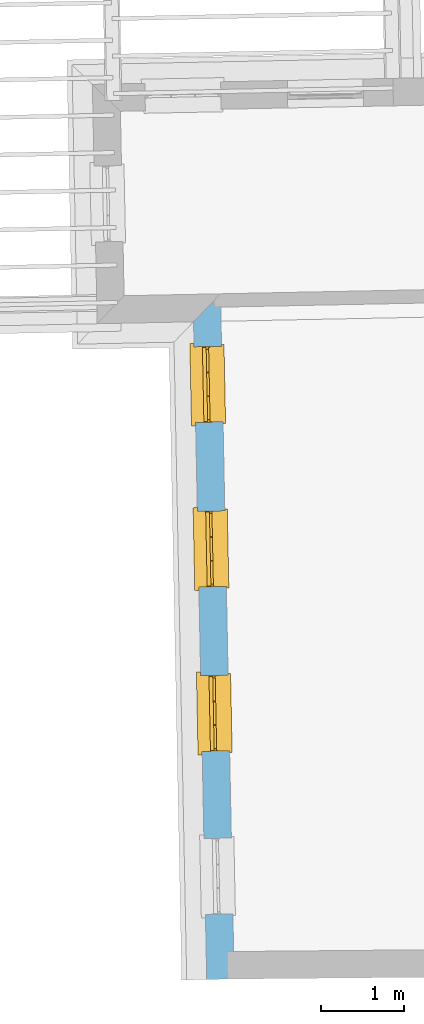
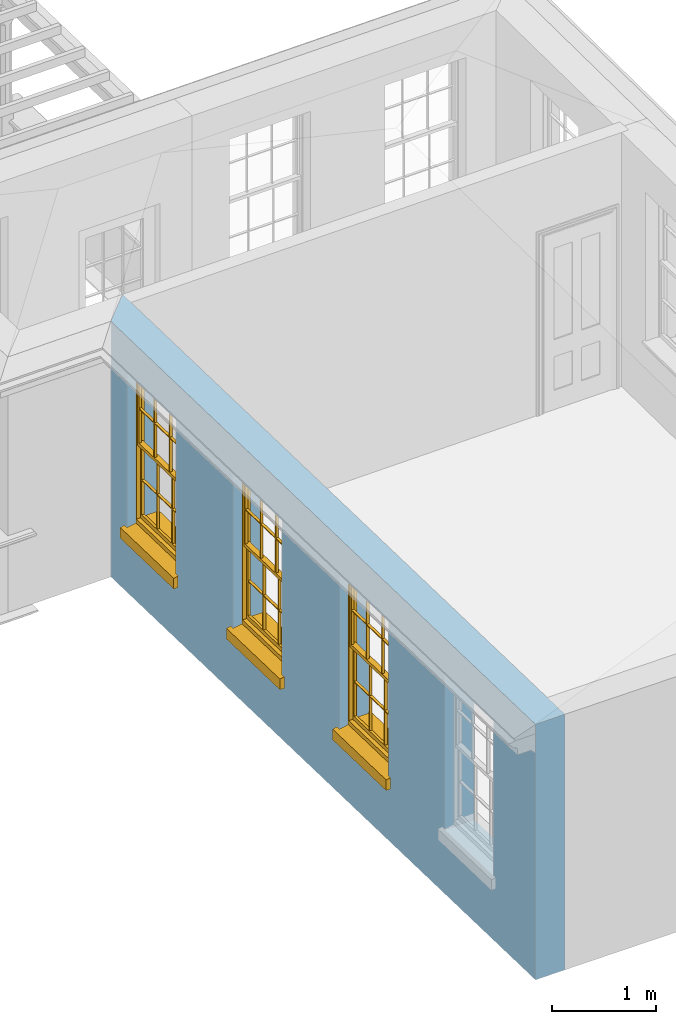
# One storey, part 2 of 11: 3 windows, 4 openings, plus 1 element that does not belong to this part.
"""IFC2X3 building model written with IfcOpenShell, lengths in metres."""

from ifc_helpers import new_model, si_unit, frame, origin, place, context, subcontext, project, spatial, polyline, outline, extrude, faceted_brep, material, layer, layer_set, layer_usage, element, fill, save


model = new_model("IFC2X3")

# Units and contexts
model_context = context("Model", 3, world=origin())
body_context = subcontext(model_context, "Body", "Model", "MODEL_VIEW")
ifc_project = project(units=[si_unit("PLANEANGLEUNIT", "RADIAN"), si_unit("MASSUNIT", "GRAM", prefix="KILO"), si_unit("FORCEUNIT", "NEWTON", prefix="KILO"), si_unit("LENGTHUNIT", "METRE")], contexts=[model_context])

# Site, building, storey
site_placement = place(None, origin())
site = spatial("IfcSite", under=ifc_project, at=site_placement, CompositionType="ELEMENT")
building_placement = place(None, origin())
building = spatial("IfcBuilding", under=site, at=building_placement, Name="Building plot-11", CompositionType="ELEMENT")
storey_placement = place(None, frame((0.0, 0.0, 5.3)))
storey = spatial("IfcBuildingStorey", under=building, at=storey_placement, Name="Floor 1", CompositionType="ELEMENT", Elevation=5.3)

# Wall, openings, windows
ifc_material = material(Name="Masonry")
ifc_layer = layer(ifc_material, 0.33, ventilated=False)
ifc_layer_set = layer_set([ifc_layer], Name="My Wall")
ifc_layer_usage = layer_usage(ifc_layer_set, "AXIS2", "NEGATIVE", 0.08)
wall_placement = place(storey_placement, origin())
wall = element("IfcWallStandardCase", 1, at=wall_placement, inside=storey, material=ifc_layer_usage, Name="exterior", context=body_context, shape_type="SweptSolid", body=[
    extrude(outline(polyline([(60.0013079950097, 20.3939615024824), (59.6779715062053, 20.057429906629), (59.8358519549038, 12.1620586222609), (60.1657859972327, 12.1686561757854), (60.0013079950097, 20.3939615024824)])), origin(), (0.0, 0.0, 1.0), 3.0),
])
opening_1_placement = place(storey_placement, frame((0.0, 0.0, 0.75)))
opening_1 = element("IfcOpeningElement", 2, at=opening_1_placement, cuts=wall, Name="Opening", ObjectType="Opening", context=body_context, shape_type="SweptSolid", body=[
    extrude(outline(polyline([(59.6839692821365, 19.7574898681482), (59.7021625357948, 18.847671751423), (60.0320965781237, 18.8542693049475), (60.0139033244655, 19.7640874216726), (59.6839692821365, 19.7574898681482)])), origin(), (0.0, 0.0, 1.0), 1.82),
])
opening_2_placement = place(storey_placement, frame((0.0, 0.0, 0.75)))
opening_2 = element("IfcOpeningElement", 3, at=opening_2_placement, cuts=wall, Name="Opening", ObjectType="Opening", context=body_context, shape_type="SweptSolid", body=[
    extrude(outline(polyline([(59.7234393943112, 17.7836470470562), (59.7416326479694, 16.873828930331), (60.0715666902983, 16.8804264838554), (60.0533734366401, 17.7902446005806), (59.7234393943112, 17.7836470470562)])), origin(), (0.0, 0.0, 1.0), 1.82),
])
opening_3_placement = place(storey_placement, frame((0.0, 0.0, 0.75)))
opening_3 = element("IfcOpeningElement", 4, at=opening_3_placement, cuts=wall, Name="Opening", ObjectType="Opening", context=body_context, shape_type="SweptSolid", body=[
    extrude(outline(polyline([(59.7629095064858, 15.8098042259642), (59.7811027601441, 14.899986109239), (60.111036802473, 14.9065836627634), (60.0928435488147, 15.8164017794886), (59.7629095064858, 15.8098042259642)])), origin(), (0.0, 0.0, 1.0), 1.82),
])
opening_4_placement = place(storey_placement, frame((0.0, 0.0, 0.75)))
element("IfcOpeningElement", 5, at=opening_4_placement, cuts=wall, Name="Opening", ObjectType="Opening", context=body_context, shape_type="SweptSolid", body=[
    extrude(outline(polyline([(59.8020221253779, 13.8538391232369), (59.8202153790362, 12.9440210065117), (60.1501494213651, 12.9506185600361), (60.1319561677068, 13.8604366767613), (59.8020221253779, 13.8538391232369)])), origin(), (0.0, 0.0, 1.0), 1.82),
])
window_1_placement = place(storey_placement, frame((59.9339193142039, 19.7624880147576, 0.75), z_axis=(0.0, 0.0, 1.0), x_axis=(0.0181932536582536, -0.909818116725166, 0.0)))
window_1 = element("IfcWindow", 6, at=window_1_placement, inside=storey, Name="bedroom outside window", OverallHeight=1.82, OverallWidth=0.91, context=body_context, shape_type="Brep", held_by="IfcProductRepresentation", body=[
    faceted_brep([(0.033125, -0.105, 0.975209), (0.01, -0.105, 0.975209), (0.033125, -0.105, 1.376042), (0.876875, -0.105, 0.975209), (0.876875, -0.105, 1.376042), (0.9, -0.105, 0.975209), (0.876875, -0.105, 1.386042), (0.876875, -0.105, 1.786875), (0.9, -0.105, 1.81), (0.033125, -0.105, 1.786875), (0.033125, -0.105, 1.386042), (0.01, -0.105, 1.81), (0.876875, -0.135, 1.376042), (0.876875, -0.135, 0.975209), (0.9, -0.135, 0.937083), (0.033125, -0.135, 1.786875), (0.01, -0.135, 1.81), (0.033125, -0.135, 1.386042), (0.01, -0.135, 0.937083), (0.033125, -0.135, 0.975209), (0.033125, -0.135, 1.376042), (0.876875, -0.135, 1.786875), (0.876875, -0.135, 1.386042), (0.9, -0.135, 1.81), (0.033125, -0.105, 0.937083), (0.01, -0.105, 0.937083), (0.033125, -0.105, 0.53625), (0.876875, -0.105, 0.937083), (0.876875, -0.105, 0.53625), (0.9, -0.105, 0.937083), (0.876875, -0.105, 0.52625), (0.876875, -0.105, 0.125417), (0.9, -0.105, 0.077167), (0.033125, -0.105, 0.125417), (0.033125, -0.105, 0.52625), (0.01, -0.105, 0.077167), (-0.0425, -0.25, 0.01), (-0.0425, -0.3, 0.001667), (0.0, -0.25, 0.01), (0.9525, -0.25, 0.01), (0.91, -0.25, 0.01), (0.9525, -0.3, 0.001667), (-0.02, 0.08, 0.077167), (0.0, 0.08, 0.077167), (-0.02, 0.11, 0.077167), (0.0, -0.06, 0.077167), (0.01, -0.06, 0.077167), (0.91, -0.06, 0.077167), (0.91, 0.08, 0.077167), (0.9, -0.06, 0.077167), (0.93, 0.08, 0.077167), (0.93, 0.11, 0.077167), (0.01, -0.075, 0.975209), (0.9, -0.075, 0.975209), (0.876875, -0.075, 0.125417), (0.876875, -0.075, 0.52625), (0.9, -0.075, 0.077167), (0.876875, -0.075, 0.53625), (0.876875, -0.075, 0.937083), (0.033125, -0.075, 0.125417), (0.01, -0.075, 0.077167), (0.033125, -0.075, 0.52625), (0.033125, -0.075, 0.937083), (0.033125, -0.075, 0.53625), (-0.02, 0.08, 0.052167), (-0.02, 0.11, 0.052167), (0.93, 0.11, 0.052167), (0.93, 0.08, 0.052167), (0.91, 0.08, 0.052167), (0.0, 0.08, 0.052167), (0.91, -0.15, 0.026667), (0.0, -0.15, 0.026667), (-0.0425, -0.3, -0.123333), (0.9525, -0.3, -0.123333), (-0.0425, -0.25, -0.123333), (0.9525, -0.25, -0.123333), (0.01, -0.06, 1.81), (0.9, -0.06, 1.81), (0.0, -0.06, 1.82), (0.91, -0.06, 1.82), (0.01, -0.15, 0.077167), (0.9, -0.15, 0.077167), (0.592292, -0.105, 0.125417), (0.592292, -0.075, 0.125417), (0.317708, -0.075, 0.125417), (0.317708, -0.105, 0.125417), (0.592292, -0.105, 0.53625), (0.317708, -0.105, 0.53625), (0.317708, -0.105, 0.52625), (0.592292, -0.105, 0.52625), (0.592292, -0.075, 0.53625), (0.317708, -0.075, 0.53625), (0.592292, -0.135, 1.386042), (0.592292, -0.105, 1.386042), (0.317708, -0.105, 1.386042), (0.317708, -0.135, 1.386042), (0.317708, -0.135, 1.376042), (0.592292, -0.135, 1.376042), (0.317708, -0.105, 1.376042), (0.592292, -0.105, 1.376042), (0.602292, -0.135, 1.376042), (0.592292, -0.135, 0.975209), (0.602292, -0.135, 0.975209), (0.602292, -0.105, 0.975209), (0.592292, -0.105, 0.975209), (0.602292, -0.105, 1.376042), (0.602292, -0.075, 0.53625), (0.602292, -0.105, 0.53625), (0.317708, -0.075, 0.52625), (0.307708, -0.075, 0.125417), (0.307708, -0.075, 0.52625), (0.602292, -0.075, 0.52625), (0.602292, -0.075, 0.125417), (0.592292, -0.075, 0.52625), (0.307708, -0.075, 0.53625), (0.317708, -0.075, 0.937083), (0.307708, -0.075, 0.937083), (0.602292, -0.075, 0.937083), (0.592292, -0.075, 0.937083), (0.307708, -0.105, 0.52625), (0.307708, -0.105, 0.125417), (0.307708, -0.105, 0.53625), (0.307708, -0.105, 0.937083), (0.592292, -0.105, 0.937083), (0.317708, -0.105, 0.937083), (0.602292, -0.105, 0.937083), (0.602292, -0.105, 0.52625), (0.602292, -0.105, 0.125417), (0.307708, -0.135, 1.386042), (0.307708, -0.135, 1.376042), (0.307708, -0.135, 0.975209), (0.317708, -0.135, 0.975209), (0.317708, -0.135, 1.786875), (0.307708, -0.135, 1.786875), (0.602292, -0.135, 1.786875), (0.592292, -0.135, 1.786875), (0.602292, -0.135, 1.386042), (0.602292, -0.105, 1.386042), (0.307708, -0.105, 1.386042), (0.307708, -0.105, 1.786875), (0.317708, -0.105, 1.786875), (0.592292, -0.105, 1.786875), (0.602292, -0.105, 1.786875), (0.307708, -0.105, 1.376042), (0.317708, -0.105, 0.975209), (0.307708, -0.105, 0.975209), (0.91, -0.15, 1.82), (0.9, -0.15, 1.81), (0.01, -0.15, 1.81), (0.0, -0.15, 1.82), (0.91, -0.25, 0.0), (0.0, -0.25, 0.0), (0.91, 0.08, 0.0), (0.0, 0.08, 0.0)], [[[0, 1, 2]], [[3, 4, 5]], [[6, 7, 8]], [[9, 10, 11]], [[12, 13, 14]], [[15, 16, 17]], [[18, 19, 20]], [[21, 22, 23]], [[24, 25, 26]], [[27, 28, 29]], [[30, 31, 32]], [[33, 34, 35]], [[14, 27, 29]], [[25, 24, 18]], [[36, 37, 38]], [[39, 40, 41]], [[42, 43, 44]], [[45, 46, 43]], [[47, 48, 49]], [[50, 51, 48]], [[1, 0, 52]], [[5, 53, 3]], [[54, 55, 56]], [[57, 58, 53]], [[59, 60, 61]], [[62, 63, 52]], [[48, 43, 46, 49]], [[51, 44, 43, 48]], [[64, 42, 44, 65]], [[65, 44, 51, 66]], [[66, 51, 50, 67]], [[65, 66, 68, 69]], [[60, 56, 49, 46]], [[70, 71, 38, 40]], [[37, 41, 40, 38]], [[37, 72, 73, 41]], [[74, 75, 73, 72]], [[8, 11, 76, 77]], [[76, 78, 79, 77]], [[32, 35, 80, 81]], [[81, 80, 71, 70]], [[82, 83, 84, 85]], [[86, 87, 88, 89]], [[86, 90, 91, 87]], [[92, 93, 94, 95]], [[92, 95, 96, 97]], [[96, 98, 99, 97]], [[100, 97, 101, 102]], [[103, 104, 99, 105]], [[97, 99, 104, 101]], [[102, 103, 105, 100]], [[28, 57, 106, 107]], [[108, 84, 109, 110]], [[111, 112, 83, 113]], [[114, 110, 61, 63]], [[90, 113, 108, 91]], [[115, 91, 114, 116]], [[117, 106, 90, 118]], [[111, 106, 57, 55]], [[119, 110, 109, 120]], [[34, 61, 110, 119]], [[89, 113, 83, 82]], [[88, 108, 113, 89]], [[85, 84, 108, 88]], [[121, 114, 63, 26]], [[122, 116, 114, 121]], [[123, 118, 90, 86]], [[87, 91, 115, 124]], [[107, 106, 117, 125]], [[126, 111, 55, 30]], [[127, 112, 111, 126]], [[126, 30, 28, 107]], [[88, 119, 120, 85]], [[126, 89, 82, 127]], [[125, 123, 86, 107]], [[121, 26, 34, 119]], [[124, 122, 121, 87]], [[128, 17, 20, 129]], [[96, 129, 130, 131]], [[132, 133, 128, 95]], [[134, 135, 92, 136]], [[100, 12, 22, 136]], [[137, 6, 4, 105]], [[94, 138, 139, 140]], [[137, 93, 141, 142]], [[99, 98, 94, 93]], [[143, 2, 10, 138]], [[144, 145, 143, 98]], [[129, 143, 145, 130]], [[20, 2, 143, 129]], [[131, 144, 98, 96]], [[128, 138, 10, 17]], [[133, 139, 138, 128]], [[135, 141, 93, 92]], [[95, 94, 140, 132]], [[22, 6, 137, 136]], [[136, 137, 142, 134]], [[100, 105, 4, 12]], [[107, 86, 89, 126]], [[106, 111, 113, 90]], [[91, 108, 110, 114]], [[87, 121, 119, 88]], [[97, 100, 136, 92]], [[129, 96, 95, 128]], [[98, 143, 138, 94]], [[105, 99, 93, 137]], [[131, 101, 104, 144]], [[124, 115, 118, 123]], [[132, 140, 141, 135]], [[120, 109, 59, 33]], [[15, 9, 139, 133]], [[134, 142, 7, 21]], [[31, 54, 112, 127]], [[36, 74, 72, 37]], [[39, 41, 73, 75]], [[18, 14, 101, 131]], [[23, 16, 132, 135]], [[83, 56, 60, 84]], [[52, 53, 118, 115]], [[53, 52, 144, 104]], [[11, 8, 141, 140]], [[14, 18, 124, 123]], [[2, 1, 11, 10]], [[8, 5, 4, 6]], [[57, 53, 56, 55]], [[60, 52, 63, 61]], [[26, 25, 35, 34]], [[32, 29, 28, 30]], [[14, 23, 22, 12]], [[18, 20, 17, 16]], [[19, 0, 2, 20]], [[17, 10, 9, 15]], [[12, 4, 3, 13]], [[21, 7, 6, 22]], [[27, 58, 57, 28]], [[30, 55, 54, 31]], [[33, 59, 61, 34]], [[26, 63, 62, 24]], [[5, 8, 77, 53]], [[76, 11, 1, 52]], [[46, 45, 78, 76]], [[49, 77, 79, 47]], [[70, 146, 147, 81]], [[71, 80, 148, 149]], [[19, 130, 145, 0]], [[102, 13, 3, 103]], [[116, 122, 24, 62]], [[29, 32, 81, 14]], [[80, 35, 25, 18]], [[60, 46, 76, 52]], [[77, 49, 56, 53]], [[23, 14, 81, 147]], [[16, 148, 80, 18]], [[35, 85, 120]], [[120, 33, 35]], [[127, 82, 32]], [[32, 31, 127]], [[32, 82, 85, 35]], [[102, 101, 14]], [[14, 13, 102]], [[18, 131, 130]], [[130, 19, 18]], [[134, 21, 23]], [[23, 135, 134]], [[16, 15, 133]], [[133, 132, 16]], [[11, 140, 139]], [[139, 9, 11]], [[142, 141, 8]], [[8, 7, 142]], [[23, 147, 148, 16]], [[146, 149, 148, 147]], [[52, 115, 116]], [[116, 62, 52]], [[118, 53, 117]], [[58, 117, 53]], [[27, 125, 117, 58]], [[56, 83, 112]], [[112, 54, 56]], [[109, 84, 60]], [[60, 59, 109]], [[125, 27, 14]], [[14, 123, 125]], [[122, 124, 18]], [[18, 24, 122]], [[145, 144, 52]], [[52, 0, 145]], [[103, 3, 53]], [[53, 104, 103]], [[79, 78, 149, 146]], [[78, 45, 71, 149]], [[146, 70, 47, 79]], [[150, 75, 74, 151]], [[68, 66, 67]], [[48, 68, 67, 50]], [[69, 64, 65]], [[42, 64, 69, 43]], [[69, 68, 152, 153]], [[70, 68, 48, 47]], [[150, 152, 68, 70]], [[43, 69, 71, 45]], [[69, 153, 151, 71]], [[152, 150, 151, 153]], [[38, 151, 74, 36]], [[71, 151, 38]], [[39, 75, 150, 40]], [[40, 150, 70]]]),
])
fill(opening_1, window_1)
window_2_placement = place(storey_placement, frame((59.9733894263785, 17.7886451936656, 0.75), z_axis=(0.0, 0.0, 1.0), x_axis=(0.0181932536582536, -0.909818116725166, 0.0)))
window_2 = element("IfcWindow", 7, at=window_2_placement, inside=storey, Name="bedroom outside window", OverallHeight=1.82, OverallWidth=0.91, context=body_context, shape_type="Brep", held_by="IfcProductRepresentation", body=[
    faceted_brep([(0.033125, -0.105, 0.975209), (0.01, -0.105, 0.975209), (0.033125, -0.105, 1.376042), (0.876875, -0.105, 0.975209), (0.876875, -0.105, 1.376042), (0.9, -0.105, 0.975209), (0.876875, -0.105, 1.386042), (0.876875, -0.105, 1.786875), (0.9, -0.105, 1.81), (0.033125, -0.105, 1.786875), (0.033125, -0.105, 1.386042), (0.01, -0.105, 1.81), (0.876875, -0.135, 1.376042), (0.876875, -0.135, 0.975209), (0.9, -0.135, 0.937083), (0.033125, -0.135, 1.786875), (0.01, -0.135, 1.81), (0.033125, -0.135, 1.386042), (0.01, -0.135, 0.937083), (0.033125, -0.135, 0.975209), (0.033125, -0.135, 1.376042), (0.876875, -0.135, 1.786875), (0.876875, -0.135, 1.386042), (0.9, -0.135, 1.81), (0.033125, -0.105, 0.937083), (0.01, -0.105, 0.937083), (0.033125, -0.105, 0.53625), (0.876875, -0.105, 0.937083), (0.876875, -0.105, 0.53625), (0.9, -0.105, 0.937083), (0.876875, -0.105, 0.52625), (0.876875, -0.105, 0.125417), (0.9, -0.105, 0.077167), (0.033125, -0.105, 0.125417), (0.033125, -0.105, 0.52625), (0.01, -0.105, 0.077167), (-0.0425, -0.25, 0.01), (-0.0425, -0.3, 0.001667), (0.0, -0.25, 0.01), (0.9525, -0.25, 0.01), (0.91, -0.25, 0.01), (0.9525, -0.3, 0.001667), (-0.02, 0.08, 0.077167), (0.0, 0.08, 0.077167), (-0.02, 0.11, 0.077167), (0.0, -0.06, 0.077167), (0.01, -0.06, 0.077167), (0.91, -0.06, 0.077167), (0.91, 0.08, 0.077167), (0.9, -0.06, 0.077167), (0.93, 0.08, 0.077167), (0.93, 0.11, 0.077167), (0.01, -0.075, 0.975209), (0.9, -0.075, 0.975209), (0.876875, -0.075, 0.125417), (0.876875, -0.075, 0.52625), (0.9, -0.075, 0.077167), (0.876875, -0.075, 0.53625), (0.876875, -0.075, 0.937083), (0.033125, -0.075, 0.125417), (0.01, -0.075, 0.077167), (0.033125, -0.075, 0.52625), (0.033125, -0.075, 0.937083), (0.033125, -0.075, 0.53625), (-0.02, 0.08, 0.052167), (-0.02, 0.11, 0.052167), (0.93, 0.11, 0.052167), (0.93, 0.08, 0.052167), (0.91, 0.08, 0.052167), (0.0, 0.08, 0.052167), (0.91, -0.15, 0.026667), (0.0, -0.15, 0.026667), (-0.0425, -0.3, -0.123333), (0.9525, -0.3, -0.123333), (-0.0425, -0.25, -0.123333), (0.9525, -0.25, -0.123333), (0.01, -0.06, 1.81), (0.9, -0.06, 1.81), (0.0, -0.06, 1.82), (0.91, -0.06, 1.82), (0.01, -0.15, 0.077167), (0.9, -0.15, 0.077167), (0.592292, -0.105, 0.125417), (0.592292, -0.075, 0.125417), (0.317708, -0.075, 0.125417), (0.317708, -0.105, 0.125417), (0.592292, -0.105, 0.53625), (0.317708, -0.105, 0.53625), (0.317708, -0.105, 0.52625), (0.592292, -0.105, 0.52625), (0.592292, -0.075, 0.53625), (0.317708, -0.075, 0.53625), (0.592292, -0.135, 1.386042), (0.592292, -0.105, 1.386042), (0.317708, -0.105, 1.386042), (0.317708, -0.135, 1.386042), (0.317708, -0.135, 1.376042), (0.592292, -0.135, 1.376042), (0.317708, -0.105, 1.376042), (0.592292, -0.105, 1.376042), (0.602292, -0.135, 1.376042), (0.592292, -0.135, 0.975209), (0.602292, -0.135, 0.975209), (0.602292, -0.105, 0.975209), (0.592292, -0.105, 0.975209), (0.602292, -0.105, 1.376042), (0.602292, -0.075, 0.53625), (0.602292, -0.105, 0.53625), (0.317708, -0.075, 0.52625), (0.307708, -0.075, 0.125417), (0.307708, -0.075, 0.52625), (0.602292, -0.075, 0.52625), (0.602292, -0.075, 0.125417), (0.592292, -0.075, 0.52625), (0.307708, -0.075, 0.53625), (0.317708, -0.075, 0.937083), (0.307708, -0.075, 0.937083), (0.602292, -0.075, 0.937083), (0.592292, -0.075, 0.937083), (0.307708, -0.105, 0.52625), (0.307708, -0.105, 0.125417), (0.307708, -0.105, 0.53625), (0.307708, -0.105, 0.937083), (0.592292, -0.105, 0.937083), (0.317708, -0.105, 0.937083), (0.602292, -0.105, 0.937083), (0.602292, -0.105, 0.52625), (0.602292, -0.105, 0.125417), (0.307708, -0.135, 1.386042), (0.307708, -0.135, 1.376042), (0.307708, -0.135, 0.975209), (0.317708, -0.135, 0.975209), (0.317708, -0.135, 1.786875), (0.307708, -0.135, 1.786875), (0.602292, -0.135, 1.786875), (0.592292, -0.135, 1.786875), (0.602292, -0.135, 1.386042), (0.602292, -0.105, 1.386042), (0.307708, -0.105, 1.386042), (0.307708, -0.105, 1.786875), (0.317708, -0.105, 1.786875), (0.592292, -0.105, 1.786875), (0.602292, -0.105, 1.786875), (0.307708, -0.105, 1.376042), (0.317708, -0.105, 0.975209), (0.307708, -0.105, 0.975209), (0.91, -0.15, 1.82), (0.9, -0.15, 1.81), (0.01, -0.15, 1.81), (0.0, -0.15, 1.82), (0.91, -0.25, 0.0), (0.0, -0.25, 0.0), (0.91, 0.08, 0.0), (0.0, 0.08, 0.0)], [[[0, 1, 2]], [[3, 4, 5]], [[6, 7, 8]], [[9, 10, 11]], [[12, 13, 14]], [[15, 16, 17]], [[18, 19, 20]], [[21, 22, 23]], [[24, 25, 26]], [[27, 28, 29]], [[30, 31, 32]], [[33, 34, 35]], [[14, 27, 29]], [[25, 24, 18]], [[36, 37, 38]], [[39, 40, 41]], [[42, 43, 44]], [[45, 46, 43]], [[47, 48, 49]], [[50, 51, 48]], [[1, 0, 52]], [[5, 53, 3]], [[54, 55, 56]], [[57, 58, 53]], [[59, 60, 61]], [[62, 63, 52]], [[48, 43, 46, 49]], [[51, 44, 43, 48]], [[64, 42, 44, 65]], [[65, 44, 51, 66]], [[66, 51, 50, 67]], [[65, 66, 68, 69]], [[60, 56, 49, 46]], [[70, 71, 38, 40]], [[37, 41, 40, 38]], [[37, 72, 73, 41]], [[74, 75, 73, 72]], [[8, 11, 76, 77]], [[76, 78, 79, 77]], [[32, 35, 80, 81]], [[81, 80, 71, 70]], [[82, 83, 84, 85]], [[86, 87, 88, 89]], [[86, 90, 91, 87]], [[92, 93, 94, 95]], [[92, 95, 96, 97]], [[96, 98, 99, 97]], [[100, 97, 101, 102]], [[103, 104, 99, 105]], [[97, 99, 104, 101]], [[102, 103, 105, 100]], [[28, 57, 106, 107]], [[108, 84, 109, 110]], [[111, 112, 83, 113]], [[114, 110, 61, 63]], [[90, 113, 108, 91]], [[115, 91, 114, 116]], [[117, 106, 90, 118]], [[111, 106, 57, 55]], [[119, 110, 109, 120]], [[34, 61, 110, 119]], [[89, 113, 83, 82]], [[88, 108, 113, 89]], [[85, 84, 108, 88]], [[121, 114, 63, 26]], [[122, 116, 114, 121]], [[123, 118, 90, 86]], [[87, 91, 115, 124]], [[107, 106, 117, 125]], [[126, 111, 55, 30]], [[127, 112, 111, 126]], [[126, 30, 28, 107]], [[88, 119, 120, 85]], [[126, 89, 82, 127]], [[125, 123, 86, 107]], [[121, 26, 34, 119]], [[124, 122, 121, 87]], [[128, 17, 20, 129]], [[96, 129, 130, 131]], [[132, 133, 128, 95]], [[134, 135, 92, 136]], [[100, 12, 22, 136]], [[137, 6, 4, 105]], [[94, 138, 139, 140]], [[137, 93, 141, 142]], [[99, 98, 94, 93]], [[143, 2, 10, 138]], [[144, 145, 143, 98]], [[129, 143, 145, 130]], [[20, 2, 143, 129]], [[131, 144, 98, 96]], [[128, 138, 10, 17]], [[133, 139, 138, 128]], [[135, 141, 93, 92]], [[95, 94, 140, 132]], [[22, 6, 137, 136]], [[136, 137, 142, 134]], [[100, 105, 4, 12]], [[107, 86, 89, 126]], [[106, 111, 113, 90]], [[91, 108, 110, 114]], [[87, 121, 119, 88]], [[97, 100, 136, 92]], [[129, 96, 95, 128]], [[98, 143, 138, 94]], [[105, 99, 93, 137]], [[131, 101, 104, 144]], [[124, 115, 118, 123]], [[132, 140, 141, 135]], [[120, 109, 59, 33]], [[15, 9, 139, 133]], [[134, 142, 7, 21]], [[31, 54, 112, 127]], [[36, 74, 72, 37]], [[39, 41, 73, 75]], [[18, 14, 101, 131]], [[23, 16, 132, 135]], [[83, 56, 60, 84]], [[52, 53, 118, 115]], [[53, 52, 144, 104]], [[11, 8, 141, 140]], [[14, 18, 124, 123]], [[2, 1, 11, 10]], [[8, 5, 4, 6]], [[57, 53, 56, 55]], [[60, 52, 63, 61]], [[26, 25, 35, 34]], [[32, 29, 28, 30]], [[14, 23, 22, 12]], [[18, 20, 17, 16]], [[19, 0, 2, 20]], [[17, 10, 9, 15]], [[12, 4, 3, 13]], [[21, 7, 6, 22]], [[27, 58, 57, 28]], [[30, 55, 54, 31]], [[33, 59, 61, 34]], [[26, 63, 62, 24]], [[5, 8, 77, 53]], [[76, 11, 1, 52]], [[46, 45, 78, 76]], [[49, 77, 79, 47]], [[70, 146, 147, 81]], [[71, 80, 148, 149]], [[19, 130, 145, 0]], [[102, 13, 3, 103]], [[116, 122, 24, 62]], [[29, 32, 81, 14]], [[80, 35, 25, 18]], [[60, 46, 76, 52]], [[77, 49, 56, 53]], [[23, 14, 81, 147]], [[16, 148, 80, 18]], [[35, 85, 120]], [[120, 33, 35]], [[127, 82, 32]], [[32, 31, 127]], [[32, 82, 85, 35]], [[102, 101, 14]], [[14, 13, 102]], [[18, 131, 130]], [[130, 19, 18]], [[134, 21, 23]], [[23, 135, 134]], [[16, 15, 133]], [[133, 132, 16]], [[11, 140, 139]], [[139, 9, 11]], [[142, 141, 8]], [[8, 7, 142]], [[23, 147, 148, 16]], [[146, 149, 148, 147]], [[52, 115, 116]], [[116, 62, 52]], [[118, 53, 117]], [[58, 117, 53]], [[27, 125, 117, 58]], [[56, 83, 112]], [[112, 54, 56]], [[109, 84, 60]], [[60, 59, 109]], [[125, 27, 14]], [[14, 123, 125]], [[122, 124, 18]], [[18, 24, 122]], [[145, 144, 52]], [[52, 0, 145]], [[103, 3, 53]], [[53, 104, 103]], [[79, 78, 149, 146]], [[78, 45, 71, 149]], [[146, 70, 47, 79]], [[150, 75, 74, 151]], [[68, 66, 67]], [[48, 68, 67, 50]], [[69, 64, 65]], [[42, 64, 69, 43]], [[69, 68, 152, 153]], [[70, 68, 48, 47]], [[150, 152, 68, 70]], [[43, 69, 71, 45]], [[69, 153, 151, 71]], [[152, 150, 151, 153]], [[38, 151, 74, 36]], [[71, 151, 38]], [[39, 75, 150, 40]], [[40, 150, 70]]]),
])
fill(opening_2, window_2)
window_3_placement = place(storey_placement, frame((60.0128595385532, 15.8148023725736, 0.75), z_axis=(0.0, 0.0, 1.0), x_axis=(0.0181932536582536, -0.909818116725166, 0.0)))
window_3 = element("IfcWindow", 8, at=window_3_placement, inside=storey, Name="bedroom outside window", OverallHeight=1.82, OverallWidth=0.91, context=body_context, shape_type="Brep", held_by="IfcProductRepresentation", body=[
    faceted_brep([(0.033125, -0.105, 0.975209), (0.01, -0.105, 0.975209), (0.033125, -0.105, 1.376042), (0.876875, -0.105, 0.975209), (0.876875, -0.105, 1.376042), (0.9, -0.105, 0.975209), (0.876875, -0.105, 1.386042), (0.876875, -0.105, 1.786875), (0.9, -0.105, 1.81), (0.033125, -0.105, 1.786875), (0.033125, -0.105, 1.386042), (0.01, -0.105, 1.81), (0.876875, -0.135, 1.376042), (0.876875, -0.135, 0.975209), (0.9, -0.135, 0.937083), (0.033125, -0.135, 1.786875), (0.01, -0.135, 1.81), (0.033125, -0.135, 1.386042), (0.01, -0.135, 0.937083), (0.033125, -0.135, 0.975209), (0.033125, -0.135, 1.376042), (0.876875, -0.135, 1.786875), (0.876875, -0.135, 1.386042), (0.9, -0.135, 1.81), (0.033125, -0.105, 0.937083), (0.01, -0.105, 0.937083), (0.033125, -0.105, 0.53625), (0.876875, -0.105, 0.937083), (0.876875, -0.105, 0.53625), (0.9, -0.105, 0.937083), (0.876875, -0.105, 0.52625), (0.876875, -0.105, 0.125417), (0.9, -0.105, 0.077167), (0.033125, -0.105, 0.125417), (0.033125, -0.105, 0.52625), (0.01, -0.105, 0.077167), (-0.0425, -0.25, 0.01), (-0.0425, -0.3, 0.001667), (0.0, -0.25, 0.01), (0.9525, -0.25, 0.01), (0.91, -0.25, 0.01), (0.9525, -0.3, 0.001667), (-0.02, 0.08, 0.077167), (0.0, 0.08, 0.077167), (-0.02, 0.11, 0.077167), (0.0, -0.06, 0.077167), (0.01, -0.06, 0.077167), (0.91, -0.06, 0.077167), (0.91, 0.08, 0.077167), (0.9, -0.06, 0.077167), (0.93, 0.08, 0.077167), (0.93, 0.11, 0.077167), (0.01, -0.075, 0.975209), (0.9, -0.075, 0.975209), (0.876875, -0.075, 0.125417), (0.876875, -0.075, 0.52625), (0.9, -0.075, 0.077167), (0.876875, -0.075, 0.53625), (0.876875, -0.075, 0.937083), (0.033125, -0.075, 0.125417), (0.01, -0.075, 0.077167), (0.033125, -0.075, 0.52625), (0.033125, -0.075, 0.937083), (0.033125, -0.075, 0.53625), (-0.02, 0.08, 0.052167), (-0.02, 0.11, 0.052167), (0.93, 0.11, 0.052167), (0.93, 0.08, 0.052167), (0.91, 0.08, 0.052167), (0.0, 0.08, 0.052167), (0.91, -0.15, 0.026667), (0.0, -0.15, 0.026667), (-0.0425, -0.3, -0.123333), (0.9525, -0.3, -0.123333), (-0.0425, -0.25, -0.123333), (0.9525, -0.25, -0.123333), (0.01, -0.06, 1.81), (0.9, -0.06, 1.81), (0.0, -0.06, 1.82), (0.91, -0.06, 1.82), (0.01, -0.15, 0.077167), (0.9, -0.15, 0.077167), (0.592292, -0.105, 0.125417), (0.592292, -0.075, 0.125417), (0.317708, -0.075, 0.125417), (0.317708, -0.105, 0.125417), (0.592292, -0.105, 0.53625), (0.317708, -0.105, 0.53625), (0.317708, -0.105, 0.52625), (0.592292, -0.105, 0.52625), (0.592292, -0.075, 0.53625), (0.317708, -0.075, 0.53625), (0.592292, -0.135, 1.386042), (0.592292, -0.105, 1.386042), (0.317708, -0.105, 1.386042), (0.317708, -0.135, 1.386042), (0.317708, -0.135, 1.376042), (0.592292, -0.135, 1.376042), (0.317708, -0.105, 1.376042), (0.592292, -0.105, 1.376042), (0.602292, -0.135, 1.376042), (0.592292, -0.135, 0.975209), (0.602292, -0.135, 0.975209), (0.602292, -0.105, 0.975209), (0.592292, -0.105, 0.975209), (0.602292, -0.105, 1.376042), (0.602292, -0.075, 0.53625), (0.602292, -0.105, 0.53625), (0.317708, -0.075, 0.52625), (0.307708, -0.075, 0.125417), (0.307708, -0.075, 0.52625), (0.602292, -0.075, 0.52625), (0.602292, -0.075, 0.125417), (0.592292, -0.075, 0.52625), (0.307708, -0.075, 0.53625), (0.317708, -0.075, 0.937083), (0.307708, -0.075, 0.937083), (0.602292, -0.075, 0.937083), (0.592292, -0.075, 0.937083), (0.307708, -0.105, 0.52625), (0.307708, -0.105, 0.125417), (0.307708, -0.105, 0.53625), (0.307708, -0.105, 0.937083), (0.592292, -0.105, 0.937083), (0.317708, -0.105, 0.937083), (0.602292, -0.105, 0.937083), (0.602292, -0.105, 0.52625), (0.602292, -0.105, 0.125417), (0.307708, -0.135, 1.386042), (0.307708, -0.135, 1.376042), (0.307708, -0.135, 0.975209), (0.317708, -0.135, 0.975209), (0.317708, -0.135, 1.786875), (0.307708, -0.135, 1.786875), (0.602292, -0.135, 1.786875), (0.592292, -0.135, 1.786875), (0.602292, -0.135, 1.386042), (0.602292, -0.105, 1.386042), (0.307708, -0.105, 1.386042), (0.307708, -0.105, 1.786875), (0.317708, -0.105, 1.786875), (0.592292, -0.105, 1.786875), (0.602292, -0.105, 1.786875), (0.307708, -0.105, 1.376042), (0.317708, -0.105, 0.975209), (0.307708, -0.105, 0.975209), (0.91, -0.15, 1.82), (0.9, -0.15, 1.81), (0.01, -0.15, 1.81), (0.0, -0.15, 1.82), (0.91, -0.25, 0.0), (0.0, -0.25, 0.0), (0.91, 0.08, 0.0), (0.0, 0.08, 0.0)], [[[0, 1, 2]], [[3, 4, 5]], [[6, 7, 8]], [[9, 10, 11]], [[12, 13, 14]], [[15, 16, 17]], [[18, 19, 20]], [[21, 22, 23]], [[24, 25, 26]], [[27, 28, 29]], [[30, 31, 32]], [[33, 34, 35]], [[14, 27, 29]], [[25, 24, 18]], [[36, 37, 38]], [[39, 40, 41]], [[42, 43, 44]], [[45, 46, 43]], [[47, 48, 49]], [[50, 51, 48]], [[1, 0, 52]], [[5, 53, 3]], [[54, 55, 56]], [[57, 58, 53]], [[59, 60, 61]], [[62, 63, 52]], [[48, 43, 46, 49]], [[51, 44, 43, 48]], [[64, 42, 44, 65]], [[65, 44, 51, 66]], [[66, 51, 50, 67]], [[65, 66, 68, 69]], [[60, 56, 49, 46]], [[70, 71, 38, 40]], [[37, 41, 40, 38]], [[37, 72, 73, 41]], [[74, 75, 73, 72]], [[8, 11, 76, 77]], [[76, 78, 79, 77]], [[32, 35, 80, 81]], [[81, 80, 71, 70]], [[82, 83, 84, 85]], [[86, 87, 88, 89]], [[86, 90, 91, 87]], [[92, 93, 94, 95]], [[92, 95, 96, 97]], [[96, 98, 99, 97]], [[100, 97, 101, 102]], [[103, 104, 99, 105]], [[97, 99, 104, 101]], [[102, 103, 105, 100]], [[28, 57, 106, 107]], [[108, 84, 109, 110]], [[111, 112, 83, 113]], [[114, 110, 61, 63]], [[90, 113, 108, 91]], [[115, 91, 114, 116]], [[117, 106, 90, 118]], [[111, 106, 57, 55]], [[119, 110, 109, 120]], [[34, 61, 110, 119]], [[89, 113, 83, 82]], [[88, 108, 113, 89]], [[85, 84, 108, 88]], [[121, 114, 63, 26]], [[122, 116, 114, 121]], [[123, 118, 90, 86]], [[87, 91, 115, 124]], [[107, 106, 117, 125]], [[126, 111, 55, 30]], [[127, 112, 111, 126]], [[126, 30, 28, 107]], [[88, 119, 120, 85]], [[126, 89, 82, 127]], [[125, 123, 86, 107]], [[121, 26, 34, 119]], [[124, 122, 121, 87]], [[128, 17, 20, 129]], [[96, 129, 130, 131]], [[132, 133, 128, 95]], [[134, 135, 92, 136]], [[100, 12, 22, 136]], [[137, 6, 4, 105]], [[94, 138, 139, 140]], [[137, 93, 141, 142]], [[99, 98, 94, 93]], [[143, 2, 10, 138]], [[144, 145, 143, 98]], [[129, 143, 145, 130]], [[20, 2, 143, 129]], [[131, 144, 98, 96]], [[128, 138, 10, 17]], [[133, 139, 138, 128]], [[135, 141, 93, 92]], [[95, 94, 140, 132]], [[22, 6, 137, 136]], [[136, 137, 142, 134]], [[100, 105, 4, 12]], [[107, 86, 89, 126]], [[106, 111, 113, 90]], [[91, 108, 110, 114]], [[87, 121, 119, 88]], [[97, 100, 136, 92]], [[129, 96, 95, 128]], [[98, 143, 138, 94]], [[105, 99, 93, 137]], [[131, 101, 104, 144]], [[124, 115, 118, 123]], [[132, 140, 141, 135]], [[120, 109, 59, 33]], [[15, 9, 139, 133]], [[134, 142, 7, 21]], [[31, 54, 112, 127]], [[36, 74, 72, 37]], [[39, 41, 73, 75]], [[18, 14, 101, 131]], [[23, 16, 132, 135]], [[83, 56, 60, 84]], [[52, 53, 118, 115]], [[53, 52, 144, 104]], [[11, 8, 141, 140]], [[14, 18, 124, 123]], [[2, 1, 11, 10]], [[8, 5, 4, 6]], [[57, 53, 56, 55]], [[60, 52, 63, 61]], [[26, 25, 35, 34]], [[32, 29, 28, 30]], [[14, 23, 22, 12]], [[18, 20, 17, 16]], [[19, 0, 2, 20]], [[17, 10, 9, 15]], [[12, 4, 3, 13]], [[21, 7, 6, 22]], [[27, 58, 57, 28]], [[30, 55, 54, 31]], [[33, 59, 61, 34]], [[26, 63, 62, 24]], [[5, 8, 77, 53]], [[76, 11, 1, 52]], [[46, 45, 78, 76]], [[49, 77, 79, 47]], [[70, 146, 147, 81]], [[71, 80, 148, 149]], [[19, 130, 145, 0]], [[102, 13, 3, 103]], [[116, 122, 24, 62]], [[29, 32, 81, 14]], [[80, 35, 25, 18]], [[60, 46, 76, 52]], [[77, 49, 56, 53]], [[23, 14, 81, 147]], [[16, 148, 80, 18]], [[35, 85, 120]], [[120, 33, 35]], [[127, 82, 32]], [[32, 31, 127]], [[32, 82, 85, 35]], [[102, 101, 14]], [[14, 13, 102]], [[18, 131, 130]], [[130, 19, 18]], [[134, 21, 23]], [[23, 135, 134]], [[16, 15, 133]], [[133, 132, 16]], [[11, 140, 139]], [[139, 9, 11]], [[142, 141, 8]], [[8, 7, 142]], [[23, 147, 148, 16]], [[146, 149, 148, 147]], [[52, 115, 116]], [[116, 62, 52]], [[118, 53, 117]], [[58, 117, 53]], [[27, 125, 117, 58]], [[56, 83, 112]], [[112, 54, 56]], [[109, 84, 60]], [[60, 59, 109]], [[125, 27, 14]], [[14, 123, 125]], [[122, 124, 18]], [[18, 24, 122]], [[145, 144, 52]], [[52, 0, 145]], [[103, 3, 53]], [[53, 104, 103]], [[79, 78, 149, 146]], [[78, 45, 71, 149]], [[146, 70, 47, 79]], [[150, 75, 74, 151]], [[68, 66, 67]], [[48, 68, 67, 50]], [[69, 64, 65]], [[42, 64, 69, 43]], [[69, 68, 152, 153]], [[70, 68, 48, 47]], [[150, 152, 68, 70]], [[43, 69, 71, 45]], [[69, 153, 151, 71]], [[152, 150, 151, 153]], [[38, 151, 74, 36]], [[71, 151, 38]], [[39, 75, 150, 40]], [[40, 150, 70]]]),
])
fill(opening_3, window_3)

save(model, "model.ifc")
